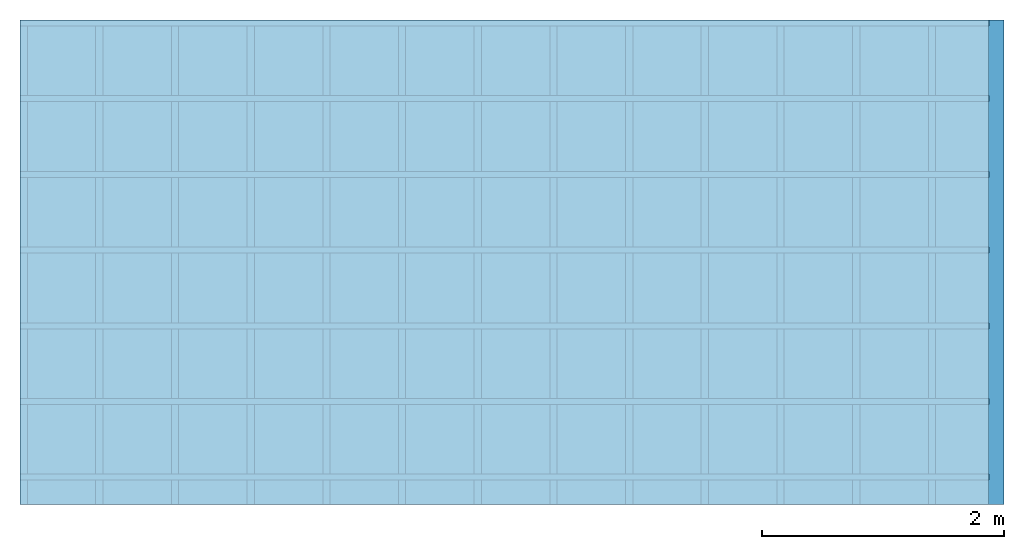
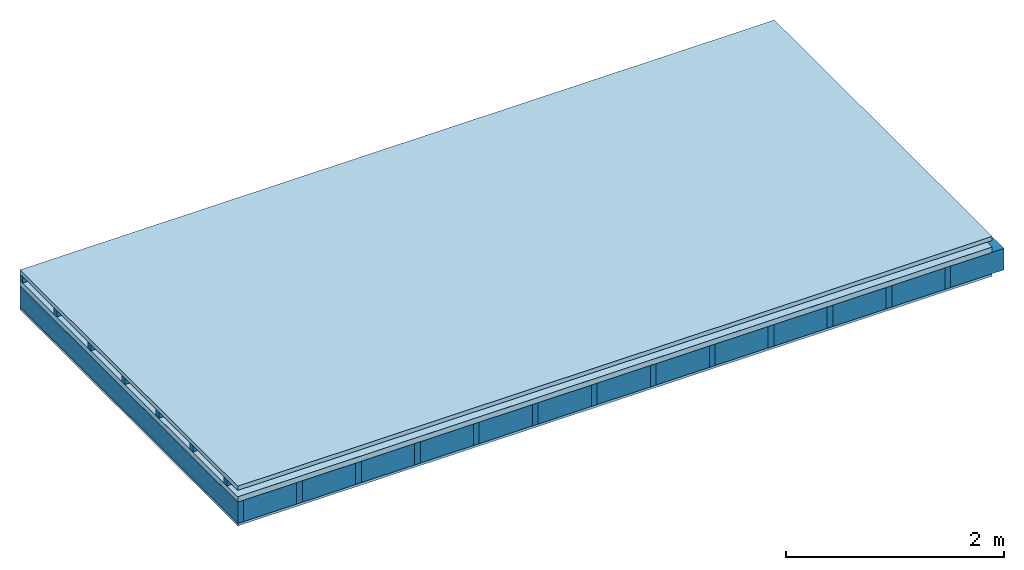
# One storey: 4 plates, 3 members, 1 element without a shape of its own.
"""IFC4 building model written with IfcOpenShell, lengths in metres."""

from ifc_helpers import new_model, si_unit, derived_unit, direction, frame, frame_2d, origin, origin_with_axes, place, context, project, spatial, rectangle, extrude, material, layer, layer_set, type_object, element, aggregate, save


model = new_model("IFC4")

# Units and contexts
plan_context = context("Plan", 3, precision=1e-05, world=origin(), true_north=direction((0.0, 1.0)))
model_context = context("Model", 3, precision=1e-05, world=origin(), true_north=direction((0.0, 1.0)))
ifc_project = project(units=[si_unit("LENGTHUNIT", "METRE"), derived_unit("SOUNDPRESSUREUNIT", [(si_unit("PRESSUREUNIT", "PASCAL", prefix="MICRO"), 0)]), si_unit("ENERGYUNIT", "JOULE", prefix="MEGA"), si_unit("MASSUNIT", "GRAM", prefix="KILO"), derived_unit("THERMALTRANSMITTANCEUNIT", [(si_unit("POWERUNIT", "WATT"), 1), (si_unit("AREAUNIT", "SQUARE_METRE"), -1), (si_unit("THERMODYNAMICTEMPERATUREUNIT", "KELVIN"), -1)]), derived_unit("AREADENSITYUNIT", [(si_unit("MASSUNIT", "GRAM", prefix="KILO"), 1), (si_unit("AREAUNIT", "SQUARE_METRE"), -1)]), derived_unit("USERDEFINED", [(si_unit("ENERGYUNIT", "JOULE", prefix="MEGA"), 1), (si_unit("AREAUNIT", "SQUARE_METRE"), -1)])], contexts=[plan_context, model_context])

# Site, building, storey
site = spatial("IfcSite", under=ifc_project)
building_placement = place(None, origin())
building = spatial("IfcBuilding", under=site, at=building_placement)
storey_placement = place(building_placement, origin())
storey = spatial("IfcBuildingStorey", under=building, at=storey_placement)

# Slab, members, plates
ifc_material_1 = material(Name="Roof tiles", Category="03.015")
ifc_layer_1 = layer(ifc_material_1, 0.047, Name="Roofing")
ifc_layer_2 = layer(None, 0.072, Name="Battens / profiles")
ifc_material_2 = material(Name="Roofing underlay", Category="09.008")
ifc_layer_3 = layer(ifc_material_2, 0.00018, Name="Under the roof")
ifc_material_3 = material(Category="10.009")
ifc_layer_4 = layer(ifc_material_3, 0.06, Name="Exterior insulation layer 1")
ifc_material_4 = material(Name="no composite action")
ifc_layer_5 = layer(ifc_material_4, 0.0, Name="Bond")
ifc_layer_6 = layer(None, 0.24, Name="Supporting structure")
ifc_material_5 = material(Name="of the art")
ifc_layer_7 = layer(ifc_material_5, 0.0, Name="Bond")
ifc_material_6 = material(Category="07.001")
ifc_layer_8 = layer(ifc_material_6, 0.027, Name="Lower layer 1")
ifc_layer_set = layer_set([ifc_layer_1, ifc_layer_2, ifc_layer_3, ifc_layer_4, ifc_layer_5, ifc_layer_6, ifc_layer_7, ifc_layer_8])
slab_type = type_object("IfcSlabType", Name="E0105", PredefinedType="NOTDEFINED", material=ifc_layer_set)
slab_placement = place(None, frame((0.0, 0.0, 0.0), z_axis=(0.0, 0.0, -1.0), x_axis=(1.0, 0.0, 0.0)))
slab = element("IfcSlab", 1, at=slab_placement, inside=storey, type_object=slab_type, material=ifc_layer_set, Name="Slab #1")
ifc_material_7 = material()
member_1_placement = place(slab_placement, origin())
member_1 = element("IfcMember", 2, at=member_1_placement, material=ifc_material_7, Name="Battens / profiles", context=plan_context, shape_type="SweptSolid", body=[
    extrude(rectangle(XDim=0.05, YDim=0.072, at=frame_2d((0.025, 0.036), x_axis=(1.0, 0.0))), frame((0.0, 0.0, 0.047), z_axis=(1.0, 0.0, 0.0), x_axis=(0.0, 1.0, 0.0)), (0.0, 0.0, 1.0), 8.0),
    extrude(rectangle(XDim=0.05, YDim=0.072, at=frame_2d((0.025, 0.036), x_axis=(1.0, 0.0))), frame((0.0, 0.625, 0.047), z_axis=(1.0, 0.0, 0.0), x_axis=(0.0, 1.0, 0.0)), (0.0, 0.0, 1.0), 8.0),
    extrude(rectangle(XDim=0.05, YDim=0.072, at=frame_2d((0.025, 0.036), x_axis=(1.0, 0.0))), frame((0.0, 1.25, 0.047), z_axis=(1.0, 0.0, 0.0), x_axis=(0.0, 1.0, 0.0)), (0.0, 0.0, 1.0), 8.0),
    extrude(rectangle(XDim=0.05, YDim=0.072, at=frame_2d((0.025, 0.036), x_axis=(1.0, 0.0))), frame((0.0, 1.875, 0.047), z_axis=(1.0, 0.0, 0.0), x_axis=(0.0, 1.0, 0.0)), (0.0, 0.0, 1.0), 8.0),
    extrude(rectangle(XDim=0.05, YDim=0.072, at=frame_2d((0.025, 0.036), x_axis=(1.0, 0.0))), frame((0.0, 2.5, 0.047), z_axis=(1.0, 0.0, 0.0), x_axis=(0.0, 1.0, 0.0)), (0.0, 0.0, 1.0), 8.0),
    extrude(rectangle(XDim=0.05, YDim=0.072, at=frame_2d((0.025, 0.036), x_axis=(1.0, 0.0))), frame((0.0, 3.125, 0.047), z_axis=(1.0, 0.0, 0.0), x_axis=(0.0, 1.0, 0.0)), (0.0, 0.0, 1.0), 8.0),
    extrude(rectangle(XDim=0.05, YDim=0.072, at=frame_2d((0.025, 0.036), x_axis=(1.0, 0.0))), frame((0.0, 3.75, 0.047), z_axis=(1.0, 0.0, 0.0), x_axis=(0.0, 1.0, 0.0)), (0.0, 0.0, 1.0), 8.0),
])
ifc_material_8 = material()
member_2_placement = place(slab_placement, origin())
member_2 = element("IfcMember", 3, at=member_2_placement, material=ifc_material_8, Name="Supporting structure", context=plan_context, shape_type="SweptSolid", body=[
    extrude(rectangle(XDim=0.06, YDim=0.24, at=frame_2d((0.03, 0.12), x_axis=(1.0, 0.0))), frame((0.0, 4.0, 0.17918), z_axis=(0.0, -1.0, 0.0), x_axis=(1.0, 0.0, 0.0)), (0.0, 0.0, 1.0), 4.0),
    extrude(rectangle(XDim=0.06, YDim=0.24, at=frame_2d((0.03, 0.12), x_axis=(1.0, 0.0))), frame((0.625, 4.0, 0.17918), z_axis=(0.0, -1.0, 0.0), x_axis=(1.0, 0.0, 0.0)), (0.0, 0.0, 1.0), 4.0),
    extrude(rectangle(XDim=0.06, YDim=0.24, at=frame_2d((0.03, 0.12), x_axis=(1.0, 0.0))), frame((1.25, 4.0, 0.17918), z_axis=(0.0, -1.0, 0.0), x_axis=(1.0, 0.0, 0.0)), (0.0, 0.0, 1.0), 4.0),
    extrude(rectangle(XDim=0.06, YDim=0.24, at=frame_2d((0.03, 0.12), x_axis=(1.0, 0.0))), frame((1.875, 4.0, 0.17918), z_axis=(0.0, -1.0, 0.0), x_axis=(1.0, 0.0, 0.0)), (0.0, 0.0, 1.0), 4.0),
    extrude(rectangle(XDim=0.06, YDim=0.24, at=frame_2d((0.03, 0.12), x_axis=(1.0, 0.0))), frame((2.5, 4.0, 0.17918), z_axis=(0.0, -1.0, 0.0), x_axis=(1.0, 0.0, 0.0)), (0.0, 0.0, 1.0), 4.0),
    extrude(rectangle(XDim=0.06, YDim=0.24, at=frame_2d((0.03, 0.12), x_axis=(1.0, 0.0))), frame((3.125, 4.0, 0.17918), z_axis=(0.0, -1.0, 0.0), x_axis=(1.0, 0.0, 0.0)), (0.0, 0.0, 1.0), 4.0),
    extrude(rectangle(XDim=0.06, YDim=0.24, at=frame_2d((0.03, 0.12), x_axis=(1.0, 0.0))), frame((3.75, 4.0, 0.17918), z_axis=(0.0, -1.0, 0.0), x_axis=(1.0, 0.0, 0.0)), (0.0, 0.0, 1.0), 4.0),
    extrude(rectangle(XDim=0.06, YDim=0.24, at=frame_2d((0.03, 0.12), x_axis=(1.0, 0.0))), frame((4.375, 4.0, 0.17918), z_axis=(0.0, -1.0, 0.0), x_axis=(1.0, 0.0, 0.0)), (0.0, 0.0, 1.0), 4.0),
    extrude(rectangle(XDim=0.06, YDim=0.24, at=frame_2d((0.03, 0.12), x_axis=(1.0, 0.0))), frame((5.0, 4.0, 0.17918), z_axis=(0.0, -1.0, 0.0), x_axis=(1.0, 0.0, 0.0)), (0.0, 0.0, 1.0), 4.0),
    extrude(rectangle(XDim=0.06, YDim=0.24, at=frame_2d((0.03, 0.12), x_axis=(1.0, 0.0))), frame((5.625, 4.0, 0.17918), z_axis=(0.0, -1.0, 0.0), x_axis=(1.0, 0.0, 0.0)), (0.0, 0.0, 1.0), 4.0),
    extrude(rectangle(XDim=0.06, YDim=0.24, at=frame_2d((0.03, 0.12), x_axis=(1.0, 0.0))), frame((6.25, 4.0, 0.17918), z_axis=(0.0, -1.0, 0.0), x_axis=(1.0, 0.0, 0.0)), (0.0, 0.0, 1.0), 4.0),
    extrude(rectangle(XDim=0.06, YDim=0.24, at=frame_2d((0.03, 0.12), x_axis=(1.0, 0.0))), frame((6.875, 4.0, 0.17918), z_axis=(0.0, -1.0, 0.0), x_axis=(1.0, 0.0, 0.0)), (0.0, 0.0, 1.0), 4.0),
    extrude(rectangle(XDim=0.06, YDim=0.24, at=frame_2d((0.03, 0.12), x_axis=(1.0, 0.0))), frame((7.5, 4.0, 0.17918), z_axis=(0.0, -1.0, 0.0), x_axis=(1.0, 0.0, 0.0)), (0.0, 0.0, 1.0), 4.0),
])
ifc_material_9 = material()
member_3_placement = place(slab_placement, origin())
member_3 = element("IfcMember", 4, at=member_3_placement, material=ifc_material_9, Name="Cavity", context=plan_context, shape_type="SweptSolid", body=[
    extrude(rectangle(XDim=0.565, YDim=0.24, at=frame_2d((0.2825, 0.12), x_axis=(1.0, 0.0))), frame((0.06, 4.0, 0.17918), z_axis=(0.0, -1.0, 0.0), x_axis=(1.0, 0.0, 0.0)), (0.0, 0.0, 1.0), 4.0),
    extrude(rectangle(XDim=0.565, YDim=0.24, at=frame_2d((0.2825, 0.12), x_axis=(1.0, 0.0))), frame((0.685, 4.0, 0.17918), z_axis=(0.0, -1.0, 0.0), x_axis=(1.0, 0.0, 0.0)), (0.0, 0.0, 1.0), 4.0),
    extrude(rectangle(XDim=0.565, YDim=0.24, at=frame_2d((0.2825, 0.12), x_axis=(1.0, 0.0))), frame((1.31, 4.0, 0.17918), z_axis=(0.0, -1.0, 0.0), x_axis=(1.0, 0.0, 0.0)), (0.0, 0.0, 1.0), 4.0),
    extrude(rectangle(XDim=0.565, YDim=0.24, at=frame_2d((0.2825, 0.12), x_axis=(1.0, 0.0))), frame((1.935, 4.0, 0.17918), z_axis=(0.0, -1.0, 0.0), x_axis=(1.0, 0.0, 0.0)), (0.0, 0.0, 1.0), 4.0),
    extrude(rectangle(XDim=0.565, YDim=0.24, at=frame_2d((0.2825, 0.12), x_axis=(1.0, 0.0))), frame((2.56, 4.0, 0.17918), z_axis=(0.0, -1.0, 0.0), x_axis=(1.0, 0.0, 0.0)), (0.0, 0.0, 1.0), 4.0),
    extrude(rectangle(XDim=0.565, YDim=0.24, at=frame_2d((0.2825, 0.12), x_axis=(1.0, 0.0))), frame((3.185, 4.0, 0.17918), z_axis=(0.0, -1.0, 0.0), x_axis=(1.0, 0.0, 0.0)), (0.0, 0.0, 1.0), 4.0),
    extrude(rectangle(XDim=0.565, YDim=0.24, at=frame_2d((0.2825, 0.12), x_axis=(1.0, 0.0))), frame((3.81, 4.0, 0.17918), z_axis=(0.0, -1.0, 0.0), x_axis=(1.0, 0.0, 0.0)), (0.0, 0.0, 1.0), 4.0),
    extrude(rectangle(XDim=0.565, YDim=0.24, at=frame_2d((0.2825, 0.12), x_axis=(1.0, 0.0))), frame((4.435, 4.0, 0.17918), z_axis=(0.0, -1.0, 0.0), x_axis=(1.0, 0.0, 0.0)), (0.0, 0.0, 1.0), 4.0),
    extrude(rectangle(XDim=0.565, YDim=0.24, at=frame_2d((0.2825, 0.12), x_axis=(1.0, 0.0))), frame((5.06, 4.0, 0.17918), z_axis=(0.0, -1.0, 0.0), x_axis=(1.0, 0.0, 0.0)), (0.0, 0.0, 1.0), 4.0),
    extrude(rectangle(XDim=0.565, YDim=0.24, at=frame_2d((0.2825, 0.12), x_axis=(1.0, 0.0))), frame((5.685, 4.0, 0.17918), z_axis=(0.0, -1.0, 0.0), x_axis=(1.0, 0.0, 0.0)), (0.0, 0.0, 1.0), 4.0),
    extrude(rectangle(XDim=0.565, YDim=0.24, at=frame_2d((0.2825, 0.12), x_axis=(1.0, 0.0))), frame((6.31, 4.0, 0.17918), z_axis=(0.0, -1.0, 0.0), x_axis=(1.0, 0.0, 0.0)), (0.0, 0.0, 1.0), 4.0),
    extrude(rectangle(XDim=0.565, YDim=0.24, at=frame_2d((0.2825, 0.12), x_axis=(1.0, 0.0))), frame((6.935, 4.0, 0.17918), z_axis=(0.0, -1.0, 0.0), x_axis=(1.0, 0.0, 0.0)), (0.0, 0.0, 1.0), 4.0),
    extrude(rectangle(XDim=0.565, YDim=0.24, at=frame_2d((0.2825, 0.12), x_axis=(1.0, 0.0))), frame((7.56, 4.0, 0.17918), z_axis=(0.0, -1.0, 0.0), x_axis=(1.0, 0.0, 0.0)), (0.0, 0.0, 1.0), 4.0),
])
plate_1_placement = place(slab_placement, origin())
plate_1 = element("IfcPlate", 5, at=plate_1_placement, material=ifc_material_1, Name="Roofing", context=plan_context, shape_type="SweptSolid", body=[
    extrude(rectangle(XDim=8.0, YDim=4.0, at=frame_2d((4.0, 2.0), x_axis=(1.0, 0.0))), origin_with_axes(), (0.0, 0.0, 1.0), 0.047),
])
plate_2_placement = place(slab_placement, origin())
plate_2 = element("IfcPlate", 6, at=plate_2_placement, material=ifc_material_2, Name="Under the roof", context=plan_context, shape_type="SweptSolid", body=[
    extrude(rectangle(XDim=8.0, YDim=4.0, at=frame_2d((4.0, 2.0), x_axis=(1.0, 0.0))), frame((0.0, 0.0, 0.119), z_axis=(0.0, 0.0, 1.0), x_axis=(1.0, 0.0, 0.0)), (0.0, 0.0, 1.0), 0.00018),
])
plate_3_placement = place(slab_placement, origin())
plate_3 = element("IfcPlate", 7, at=plate_3_placement, material=ifc_material_3, Name="Exterior insulation layer 1", context=plan_context, shape_type="SweptSolid", body=[
    extrude(rectangle(XDim=8.0, YDim=4.0, at=frame_2d((4.0, 2.0), x_axis=(1.0, 0.0))), frame((0.0, 0.0, 0.11918), z_axis=(0.0, 0.0, 1.0), x_axis=(1.0, 0.0, 0.0)), (0.0, 0.0, 1.0), 0.06),
])
plate_4_placement = place(slab_placement, origin())
plate_4 = element("IfcPlate", 8, at=plate_4_placement, material=ifc_material_6, Name="Lower layer 1", context=plan_context, shape_type="SweptSolid", body=[
    extrude(rectangle(XDim=8.0, YDim=4.0, at=frame_2d((4.0, 2.0), x_axis=(1.0, 0.0))), frame((0.0, 0.0, 0.41918), z_axis=(0.0, 0.0, 1.0), x_axis=(1.0, 0.0, 0.0)), (0.0, 0.0, 1.0), 0.027),
])
aggregate(slab, [plate_1, member_1, plate_2, plate_3, member_2, member_3, plate_4])

save(model, "model.ifc")
